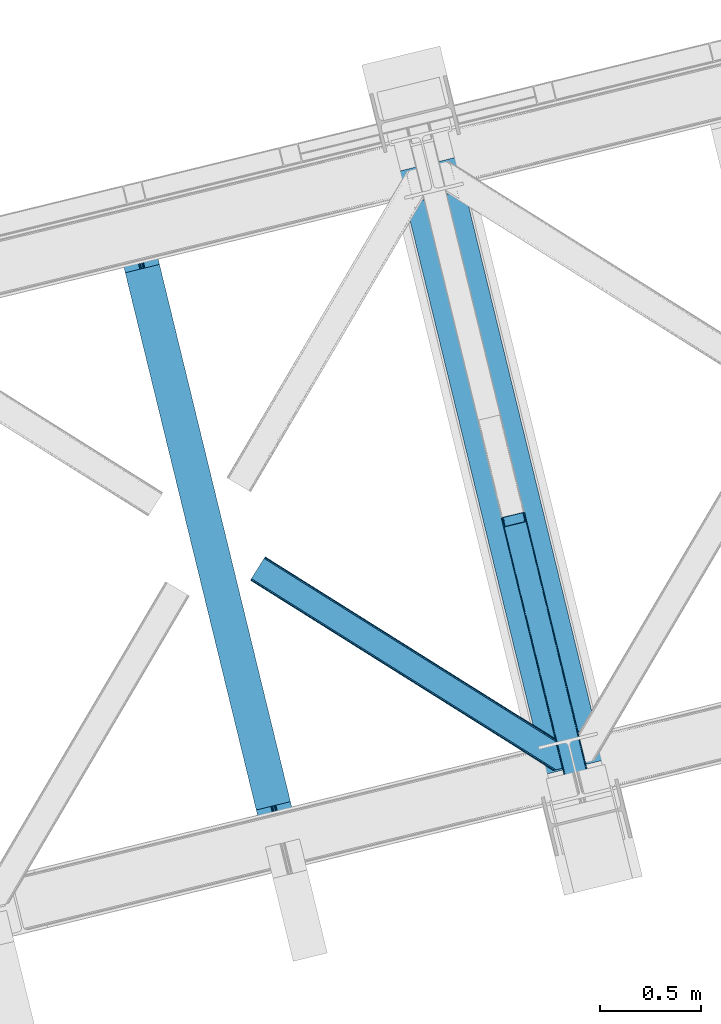
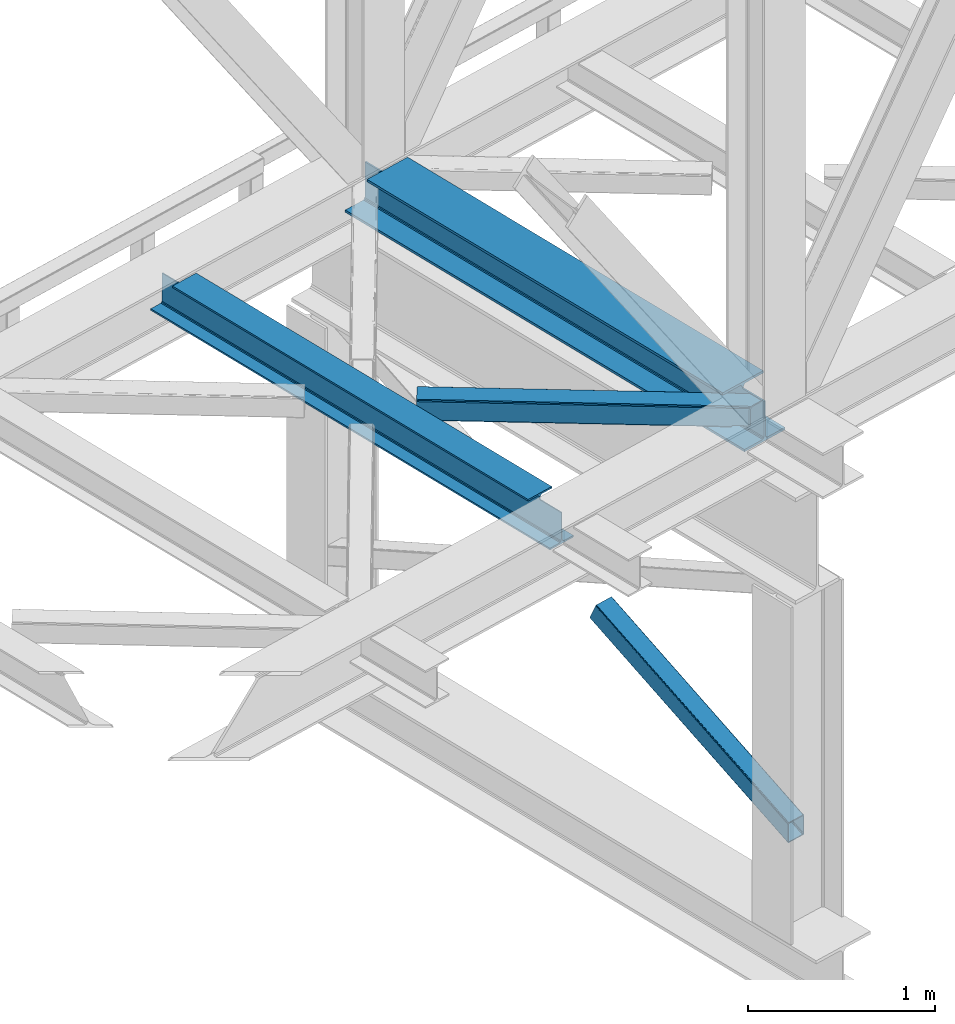
# One storey, part 28 of 93: 2 beams, 2 members.
"""IFC4 building model written with IfcOpenShell, lengths in millimetres."""

import ifcopenshell
import ifcopenshell.guid

model = None  # the IFC model being written
_history = None  # IfcOwnerHistory: only IFC2X3 demands one
_inside = {}  # id of a spatial element -> (the spatial element, [elements in it])
_under = {}  # id of a project, library or spatial element -> (it, [spatial elements below it])
_declared = {}  # id of a project -> (the project, [libraries it declares])
_typed = {}  # id of a type object -> (the type object, [elements of that type])
_made_of = {}  # id of a material, layer set ... -> (it, [elements and type objects made of it])


def new_model(schema):
    """Start an empty IFC model of exactly this schema.

    Asked for "IFC4X3", IfcOpenShell would pick the latest addendum, in which some entities
    have other attributes; the version numbers below select the first issue.
    IFC2X3 requires an IfcOwnerHistory on every rooted entity: one is made here for all.
    """
    global model, _history
    if schema == "IFC4X3":
        model = ifcopenshell.file(schema_version=(4, 3, 0, 0))
    else:
        model = ifcopenshell.file(schema=schema)
    _inside.clear()
    _under.clear()
    _declared.clear()
    _typed.clear()
    _made_of.clear()
    _history = None
    if model.schema == "IFC2X3":
        org = make("IfcOrganization", Name="unknown")
        user = make(
            "IfcPersonAndOrganization",
            ThePerson=make("IfcPerson", FamilyName="unknown"),
            TheOrganization=org,
        )
        app = make(
            "IfcApplication",
            ApplicationDeveloper=org,
            Version="unknown",
            ApplicationFullName="unknown",
            ApplicationIdentifier="unknown",
        )
        _history = make(
            "IfcOwnerHistory",
            OwningUser=user,
            OwningApplication=app,
            ChangeAction="ADDED",
            CreationDate=0,
        )
    return model


def make(cls, **values):
    """One entity of the class cls with the attributes given. An attribute that is None is left unset."""
    return model.create_entity(
        cls, **{name: value for name, value in values.items() if value is not None}
    )


def entity(cls, *values):
    """Any entity or typed value of the class cls, its attributes in the order of the schema. None: left unset."""
    e = model.create_entity(cls)
    for i, value in enumerate(values):
        if value is not None:
            e[i] = value
    return e


def rooted(cls, **values):
    """An entity with a GlobalId (a new one), such as an element, a storey or a relation."""
    return make(cls, GlobalId=ifcopenshell.guid.new(), OwnerHistory=_history, **values)


def si_unit(unit_type, name, prefix=None):
    """IfcSIUnit, for example si_unit("LENGTHUNIT", "METRE", prefix="MILLI")."""
    return make("IfcSIUnit", UnitType=unit_type, Prefix=prefix, Name=name)


def converted_unit(unit_type, name, factor, base, dimensions=None, offset=None):
    """IfcConversionBasedUnit, such as the inch: factor (a typed value) times the base unit."""
    return make(
        "IfcConversionBasedUnit"
        if offset is None
        else "IfcConversionBasedUnitWithOffset",
        ConversionOffset=offset,
        Dimensions=None
        if dimensions is None
        else entity("IfcDimensionalExponents", *dimensions),
        UnitType=unit_type,
        Name=name,
        ConversionFactor=make(
            "IfcMeasureWithUnit", ValueComponent=factor, UnitComponent=base
        ),
    )


def derived_unit(unit_type, elements):
    """IfcDerivedUnit: a product of units, each with its exponent."""
    return make(
        "IfcDerivedUnit",
        Elements=[
            make("IfcDerivedUnitElement", Unit=unit, Exponent=power)
            for unit, power in elements
        ],
        UnitType=unit_type,
    )


def assignment(units):
    """IfcUnitAssignment: the units of a project."""
    return None if units is None else make("IfcUnitAssignment", Units=units)


def point(xyz):
    """IfcCartesianPoint."""
    return None if xyz is None else make("IfcCartesianPoint", Coordinates=xyz)


def direction(xyz):
    """IfcDirection."""
    return None if xyz is None else make("IfcDirection", DirectionRatios=xyz)


def frame(location, z_axis=None, x_axis=None):
    """IfcAxis2Placement3D, a coordinate frame: its origin and axes. An axis left out is left unset."""
    return make(
        "IfcAxis2Placement3D",
        Location=point(location),
        Axis=direction(z_axis),
        RefDirection=direction(x_axis),
    )


def origin():
    """The frame at (0, 0, 0) with its axes left unset."""
    return frame((0.0, 0.0, 0.0))


def place(relative_to, where):
    """IfcLocalPlacement: puts the frame where relative to a parent placement (None: the world)."""
    return make(
        "IfcLocalPlacement", PlacementRelTo=relative_to, RelativePlacement=where
    )


def context(
    kind, dimensions, precision=None, world=None, true_north=None, identifier=None
):
    """IfcGeometricRepresentationContext, for example the 3D "Model" context."""
    return make(
        "IfcGeometricRepresentationContext",
        ContextIdentifier=identifier,
        ContextType=kind,
        CoordinateSpaceDimension=dimensions,
        Precision=precision,
        WorldCoordinateSystem=world,
        TrueNorth=true_north,
    )


def subcontext(parent, identifier, kind, view, scale=None):
    """IfcGeometricRepresentationSubContext, for example "Body" below "Model"."""
    return make(
        "IfcGeometricRepresentationSubContext",
        ContextIdentifier=identifier,
        ContextType=kind,
        ParentContext=parent,
        TargetScale=scale,
        TargetView=view,
    )


def project(units=None, contexts=None):
    """IfcProject with its units and contexts."""
    return rooted(
        "IfcProject",
        Name="project",
        RepresentationContexts=contexts,
        UnitsInContext=assignment(units),
    )


def spatial(cls, under=None, at=None, **own):
    """A site, building, storey or space (cls), placed at a placement, below another one or the project."""
    s = rooted(cls, ObjectPlacement=at, **own)
    if under is not None:
        _under.setdefault(under.id(), (under, []))[1].append(s)
    return s


def point_list(points):
    """IfcCartesianPointList2D or 3D."""
    cls = (
        "IfcCartesianPointList2D" if len(points[0]) == 2 else "IfcCartesianPointList3D"
    )
    return make(cls, CoordList=points)


def triangles(points, corners, closed=None, point_numbers=None):
    """IfcTriangulatedFaceSet: each triangle names its three corners, points numbered from 1."""
    return make(
        "IfcTriangulatedFaceSet",
        Coordinates=point_list(points),
        Closed=closed,
        CoordIndex=corners,
        PnIndex=point_numbers,
    )


def polygons(points, faces, closed=None, point_numbers=None):
    """IfcPolygonalFaceSet: a face is its outer loop, then its inner loops; points numbered from 1."""
    made = []
    for loops in faces:
        if len(loops) == 1:
            made.append(make("IfcIndexedPolygonalFace", CoordIndex=loops[0]))
        else:
            made.append(
                make(
                    "IfcIndexedPolygonalFaceWithVoids",
                    CoordIndex=loops[0],
                    InnerCoordIndices=loops[1:],
                )
            )
    return make(
        "IfcPolygonalFaceSet",
        Coordinates=point_list(points),
        Closed=closed,
        Faces=made,
        PnIndex=point_numbers,
    )


def shape(context_of_items, identifier, shape_type, items):
    """IfcShapeRepresentation: the items that make up one representation, for example the "Body"."""
    return make(
        "IfcShapeRepresentation",
        ContextOfItems=context_of_items,
        RepresentationIdentifier=identifier,
        RepresentationType=shape_type,
        Items=items,
    )


def material(Name=None, Category=None):
    """IfcMaterial."""
    return make("IfcMaterial", Name=Name, Category=Category)


def made_of(thing, what):
    """Note that an element or type object is made of a material, layer set ...; save() writes the relation."""
    if what is not None:
        _made_of.setdefault(what.id(), (what, []))[1].append(thing)
    return thing


def type_object(cls, material=None, **own):
    """A type object (cls), such as IfcWallType, which elements share."""
    return made_of(rooted(cls, **own), material)


def element(
    cls,
    number,
    at=None,
    inside=None,
    cuts=None,
    type_object=None,
    material=None,
    context=None,
    identifier="Body",
    shape_type=None,
    held_by="IfcProductDefinitionShape",
    body=None,
    shapes=None,
    **own,
):
    """One element of the class cls, such as IfcWall. Its Tag is "e" and its number.

    at: its placement. inside: the storey or other place that contains it. cuts: it is an
    opening in that element (IfcRelVoidsElement). A single representation is given by context,
    identifier, shape_type and body (its items); several are given by shapes. held_by: the class
    of the entity that holds the representations. save() writes the other relations.
    """
    e = rooted(cls, Tag="e%d" % number, ObjectPlacement=at, **own)
    if body is not None:
        shapes = [shape(context, identifier, shape_type, body)]
    if shapes is not None:
        e.Representation = make(held_by, Representations=shapes)
    if inside is not None:
        _inside.setdefault(inside.id(), (inside, []))[1].append(e)
    if cuts is not None:
        rooted(
            "IfcRelVoidsElement", RelatingBuildingElement=cuts, RelatedOpeningElement=e
        )
    if type_object is not None:
        _typed.setdefault(type_object.id(), (type_object, []))[1].append(e)
    return made_of(e, material)


def aggregate(whole, parts):
    """IfcRelAggregates: a whole, such as a stair, and the parts it consists of."""
    return rooted("IfcRelAggregates", RelatingObject=whole, RelatedObjects=parts)


def save(model, path):
    """Write the relations noted so far, then the file.

    IfcRelAggregates (storeys below a building ...), IfcRelContainedInSpatialStructure (elements
    in a storey), IfcRelDefinesByType, IfcRelAssociatesMaterial and IfcRelDeclares: one each for
    every whole, place, type object, material and project.
    """
    for whole, parts in _under.values():
        aggregate(whole, parts)
    for where, things in _inside.values():
        rooted(
            "IfcRelContainedInSpatialStructure",
            RelatedElements=things,
            RelatingStructure=where,
        )
    for kind, things in _typed.values():
        rooted("IfcRelDefinesByType", RelatedObjects=things, RelatingType=kind)
    for what, things in _made_of.values():
        rooted("IfcRelAssociatesMaterial", RelatedObjects=things, RelatingMaterial=what)
    for by, libraries in _declared.values():
        rooted("IfcRelDeclares", RelatingContext=by, RelatedDefinitions=libraries)
    model.write(path)


model = new_model("IFC4")

# Units and contexts
model_context = context("Model", 3, precision=0.01, world=origin(), true_north=direction((6.12303176911189e-17, 1.0)))
plan_context = context("Plan", 3, precision=0.01, world=origin(), true_north=direction((6.12303176911189e-17, 1.0)))
body_context = subcontext(model_context, "Body", "Model", "MODEL_VIEW")
ifc_project = project(units=[si_unit("LENGTHUNIT", "METRE", prefix="MILLI"), si_unit("AREAUNIT", "SQUARE_METRE"), si_unit("VOLUMEUNIT", "CUBIC_METRE"), converted_unit("PLANEANGLEUNIT", "DEGREE", entity("IfcRatioMeasure", 0.0174532925199433), si_unit("PLANEANGLEUNIT", "RADIAN"), dimensions=[0, 0, 0, 0, 0, 0, 0]), si_unit("MASSUNIT", "GRAM", prefix="KILO"), derived_unit("MASSDENSITYUNIT", [(si_unit("MASSUNIT", "GRAM", prefix="KILO"), 1), (si_unit("LENGTHUNIT", "METRE"), -3)]), derived_unit("MOMENTOFINERTIAUNIT", [(si_unit("LENGTHUNIT", "METRE"), 4)]), si_unit("TIMEUNIT", "SECOND"), si_unit("FREQUENCYUNIT", "HERTZ"), si_unit("THERMODYNAMICTEMPERATUREUNIT", "DEGREE_CELSIUS"), derived_unit("THERMALTRANSMITTANCEUNIT", [(si_unit("MASSUNIT", "GRAM", prefix="KILO"), 1), (si_unit("THERMODYNAMICTEMPERATUREUNIT", "KELVIN"), -1), (si_unit("TIMEUNIT", "SECOND"), -3)]), derived_unit("VOLUMETRICFLOWRATEUNIT", [(si_unit("LENGTHUNIT", "METRE"), 3), (si_unit("TIMEUNIT", "SECOND"), -1)]), derived_unit("MASSFLOWRATEUNIT", [(si_unit("MASSUNIT", "GRAM", prefix="KILO"), 1), (si_unit("TIMEUNIT", "SECOND"), -1)]), derived_unit("ROTATIONALFREQUENCYUNIT", [(si_unit("TIMEUNIT", "SECOND"), -1)]), si_unit("ELECTRICCURRENTUNIT", "AMPERE"), si_unit("ELECTRICVOLTAGEUNIT", "VOLT"), si_unit("POWERUNIT", "WATT"), si_unit("FORCEUNIT", "NEWTON", prefix="KILO"), si_unit("ILLUMINANCEUNIT", "LUX"), si_unit("LUMINOUSFLUXUNIT", "LUMEN"), si_unit("LUMINOUSINTENSITYUNIT", "CANDELA"), derived_unit("USERDEFINED", [(si_unit("MASSUNIT", "GRAM", prefix="KILO"), -1), (si_unit("LENGTHUNIT", "METRE"), -2), (si_unit("TIMEUNIT", "SECOND"), 3), (si_unit("LUMINOUSFLUXUNIT", "LUMEN"), 1)]), derived_unit("LINEARVELOCITYUNIT", [(si_unit("LENGTHUNIT", "METRE"), 1), (si_unit("TIMEUNIT", "SECOND"), -1)]), si_unit("PRESSUREUNIT", "PASCAL"), derived_unit("USERDEFINED", [(si_unit("LENGTHUNIT", "METRE"), -2), (si_unit("MASSUNIT", "GRAM", prefix="KILO"), 1), (si_unit("TIMEUNIT", "SECOND"), -2)]), derived_unit("LINEARFORCEUNIT", [(si_unit("MASSUNIT", "GRAM", prefix="KILO"), 1), (si_unit("LENGTHUNIT", "METRE"), 1), (si_unit("TIMEUNIT", "SECOND"), -2), (si_unit("LENGTHUNIT", "METRE"), -1)]), derived_unit("PLANARFORCEUNIT", [(si_unit("MASSUNIT", "GRAM", prefix="KILO"), 1), (si_unit("LENGTHUNIT", "METRE"), 1), (si_unit("TIMEUNIT", "SECOND"), -2), (si_unit("LENGTHUNIT", "METRE"), -2)])], contexts=[model_context, plan_context])

# Site, building, storey
site_placement = place(None, origin())
site = spatial("IfcSite", under=ifc_project, at=site_placement, CompositionType="ELEMENT")
building_placement = place(site_placement, origin())
building = spatial("IfcBuilding", under=site, at=building_placement, CompositionType="ELEMENT")
storey_placement = place(building_placement, frame((0.0, 0.0, 15900.0)))
storey = spatial("IfcBuildingStorey", under=building, at=storey_placement, CompositionType="ELEMENT", Elevation=15900.0)

# Beams
ifc_material = material(Name="Metal painted (White)")
beam_type = type_object("IfcBeamType", PredefinedType="BEAM")
beam_1_placement = place(storey_placement, frame((-56721.2326653712, 3960.30424291237, 3441.0)))
element("IfcBeam", 1, at=beam_1_placement, inside=storey, type_object=beam_type, material=ifc_material, ObjectType="Steel Beam", PredefinedType="BEAM", context=body_context, shape_type="Tessellation", body=[
    polygons([(900.985346189432, 41.4445662733087, 11.000000000004), (900.985346189432, 41.4445662733087, 2.16573425859679e-12), (170.021610174752, 3040.13999372697, 2.16573425859679e-12), (170.021610174752, 3040.13999372697, 11.000000000004), (834.919806235814, 25.3403919499662, 11.000000000004), (103.956070221135, 3024.03581940363, 11.000000000004), (828.971056214522, 23.8903211957401, 12.2179274798217), (98.0073201998427, 3022.5857486494, 12.2179274798217), (823.927949458422, 22.6610105689194, 15.6862915010192), (92.9642134437254, 3021.35643802258, 15.6862915010192), (820.558253255237, 21.8396114687119, 20.8770650821657), (89.5945172405581, 3020.53503892237, 20.8770650821657), (819.374973305543, 21.5511744621206, 27.0000000000047), (88.4112372908723, 3020.24660191578, 27.0000000000047), (81.6103728838801, 3018.58881926485, 27.0000000000047), (81.6103728838801, 3018.58881926485, 203.000000000006), (88.4112372908636, 3020.24660191578, 203.000000000006), (-8.66293703438714e-12, 2998.69542745366, 2.16573425859679e-12), (-8.66293703438714e-12, 2998.69542745366, 10.9999999999997), (66.0655399536172, 3014.799601777, 11.000000000004), (72.0142899749097, 3016.24967253123, 12.2179274798217), (77.0573967310183, 3017.47898315805, 15.6862915010192), (80.4270929341942, 3018.30038225826, 20.8770650821657), (819.374973305543, 21.5511744621195, 203.000000000006), (812.574108898559, 19.8933918111881, 203.000000000006), (812.574108898559, 19.8933918111881, 27.0000000000047), (811.390828948873, 19.6049548045968, 20.8770650821657), (808.021132745689, 18.7835557043887, 15.6862915010192), (802.978025989589, 17.5542450775691, 12.2179274798217), (797.029275968279, 16.1041743233431, 11.000000000004), (730.963736014671, -1.08286712929839e-12, 10.9999999999997), (730.963736014662, 0.0, 2.16573425859679e-12), (779.675212882749, 184.415062601691, 203.069791966819), (128.020401343495, 2857.75452019162, 203.000000000006), (128.243282132641, 2856.84017775719, 203.617301946336), (128.256196377177, 2856.7871977843, 217.000003693143), (779.530009633815, 185.010597404071, 217.000003676718), (779.530880241713, 185.007025963191, 204.00000679514), (772.964911718311, 182.385463974442, 203.006342981529), (772.742064056773, 183.299815969774, 203.617301946336), (772.729149812254, 183.352795942667, 217.000003693143), (121.455336555599, 2855.1293963229, 217.000003676718), (121.45446594771, 2855.13296776378, 204.00000679514), (121.310166358655, 2855.72494066435, 203.076120467494), (121.219536936503, 2856.09673754069, 203.000000000006), (780.71349435786, 185.298194377514, 223.122939328039), (784.08249076653, 186.122464201393, 228.313710402595), (789.125126170554, 187.353708426698, 231.782072735464), (795.073705041258, 188.80448128138, 232.999999602236), (861.139155906781, 204.909021065315, 232.999999283132), (861.137682570343, 204.915065042187, 243.999994005812), (691.116301666422, 163.469558245298, 243.999994827032), (691.117775002877, 163.463514268424, 233.000000104353), (757.183225868383, 179.568054052358, 232.999999785253), (763.132130996713, 181.017488520583, 231.782072861016), (768.175695503853, 182.244921343717, 228.313710479427), (771.546082413585, 183.063487001147, 223.12293937232), (120.271851831572, 2854.84179934945, 223.122939328039), (116.902855422893, 2854.01752952557, 228.313710402595), (111.860220018869, 2852.78628530027, 231.782072735464), (105.911641148157, 2851.33551244559, 232.999999602236), (39.8461902826332, 2835.23097266165, 232.999999283128), (39.8476636190708, 2835.22492868478, 243.999994005812), (209.869044522992, 2876.67043548167, 243.999994827032), (209.867571186554, 2876.67647945854, 233.000000104357), (143.802120321031, 2860.57193967461, 232.999999785253), (137.853215192701, 2859.12250520638, 231.782072861012), (132.809650685561, 2857.89507238325, 228.313710479427), (129.43926377583, 2857.07650672582, 223.12293937232)], [[[1, 2, 3, 4]], [[5, 1, 4, 6]], [[7, 5, 6, 8]], [[9, 7, 8, 10]], [[11, 9, 10, 12]], [[13, 11, 12, 14]], [[15, 16, 17, 14, 12, 10, 8, 6, 4, 3, 18, 19, 20, 21, 22, 23]], [[13, 24, 25, 26, 27, 28, 29, 30, 31, 32, 2, 1, 5, 7, 9, 11]], [[2, 32, 18, 3]], [[32, 31, 19, 18]], [[31, 30, 20, 19]], [[27, 26, 15, 23]], [[28, 27, 23, 22]], [[29, 28, 22, 21]], [[30, 29, 21, 20]], [[33, 24, 13, 14, 17, 34, 35, 36, 37, 38]], [[25, 39, 40, 41, 42, 43, 44, 16, 15, 26]], [[39, 25, 24, 33]], [[45, 34, 17, 16]], [[41, 40, 38, 37, 46, 47, 48, 49, 50, 51, 52, 53, 54, 55, 56, 57]], [[42, 58, 59, 60, 61, 62, 63, 64, 65, 66, 67, 68, 69, 36, 35, 43]], [[46, 37, 36, 69]], [[47, 46, 69, 68]], [[48, 47, 68, 67]], [[49, 48, 67, 66]], [[50, 49, 66, 65]], [[51, 50, 65, 64]], [[52, 51, 64, 63]], [[53, 52, 63, 62]], [[54, 53, 62, 61]], [[55, 54, 61, 60]], [[56, 55, 60, 59]], [[57, 56, 59, 58]], [[41, 57, 58, 42]]], closed=False),
])
beam_2_placement = place(storey_placement, frame((-55324.6265817928, 4300.74175158598, 3385.0)))
element("IfcBeam", 2, at=beam_2_placement, inside=storey, type_object=beam_type, material=ifc_material, ObjectType="Steel Beam", PredefinedType="BEAM", context=body_context, shape_type="Tessellation", body=[
    polygons([(1022.42935345713, 71.0478278971016, 15.4999999999986), (1022.42935345713, 71.0478278971016, 0.0), (291.465617442446, 3069.74325535076, 0.0), (291.465617442446, 3069.74325535076, 15.4999999999986), (899.042242073153, 40.9709140873286, 15.4999999999986), (168.078506058482, 3039.66634154099, 15.4999999999986), (892.349898299199, 39.3395844888243, 16.8701684147963), (161.38616228452, 3038.03501194248, 16.8701684147963), (886.676403198583, 37.956610033653, 20.7720779386413), (155.712667183904, 3036.65203748731, 20.7720779386413), (882.885494970008, 37.0325360459184, 26.6116982174294), (151.921758955329, 3035.72796349958, 26.6116982174294), (881.554305026603, 36.7080444135029, 33.500000000001), (150.590569011941, 3035.40347186716, 33.500000000001), (140.875048430531, 3033.03521093726, 33.500000000001), (140.875048430514, 3033.03521093726, 259.000000000002), (150.590569011924, 3035.40347186716, 259.000000000002), (8.66293703438714e-12, 2998.69542745366, 0.0), (8.66293703438714e-12, 2998.69542745366, 15.4999999999986), (123.387111383972, 3028.77234126343, 15.4999999999986), (130.079455157918, 3030.40367086194, 16.8701684147963), (135.752950258551, 3031.78664531711, 20.7720779386413), (139.543858487126, 3032.71071930484, 26.6116982174294), (881.554305026603, 36.7080444135024, 259.000000000002), (871.838784445193, 34.3397834836003, 259.000000000002), (871.838784445193, 34.3397834836003, 33.500000000001), (870.507594501796, 34.0152918511848, 26.6116982174294), (866.716686273221, 33.0912178634502, 20.7720779386413), (861.043191172614, 31.7082434082778, 16.8701684147963), (854.350847398652, 30.0769138097741, 15.4999999999986), (730.963736014679, 1.08286712929839e-12, 15.4999999999986), (730.963736014679, 0.0, 0.0), (841.85453458624, 199.57193011123, 259.069791776412), (190.199733064564, 2872.911390143, 259.000000000002), (190.423126166404, 2871.99494573803, 259.61730333112), (190.43551501003, 2871.94412150426, 266.500003008253), (841.70935577274, 200.167408132524, 266.500002998871), (841.709705893492, 200.16597182779, 260.000004007589), (832.229597305445, 196.831858094285, 259.006343172366), (832.006227290704, 197.748309612731, 259.61730333112), (831.993838447078, 197.799133846505, 266.500003008253), (180.719997684385, 2869.57584721824, 266.500002998871), (180.719647563633, 2869.57728352297, 260.000004007589), (180.574841905289, 2870.17133233676, 259.07612046749), (180.484212483145, 2870.5431292131, 259.000000000002), (843.040843642659, 200.49067757721, 273.388305639783), (846.831120231363, 201.417342749123, 279.227924098781), (852.504191178893, 202.802057212799, 283.129832400619), (859.196382860027, 204.434010743612, 284.500000377228), (982.583411547879, 234.511263798724, 284.500000138971), (982.58174174121, 234.518113867455, 299.999995328161), (691.11631964394, 163.469484603413, 299.999995890962), (691.1179894506, 163.462634534682, 284.500000701776), (814.505018138444, 193.539887589793, 284.500000463519), (821.197505034592, 195.170630056372, 283.129832461069), (826.871416683343, 196.551895700897, 279.227924137322), (830.662951470344, 197.473399350194, 273.388305663684), (179.388509814458, 2869.25257777355, 273.388305639783), (175.598233225771, 2868.32591260164, 279.227924098781), (169.925162278232, 2866.94119813796, 283.129832400619), (163.232970597099, 2865.30924460715, 284.500000377228), (39.8459419092461, 2835.23199155204, 284.500000138971), (39.8476117159065, 2835.22514148331, 299.999995328161), (331.313033813185, 2906.27377074735, 299.999995890962), (331.311364006534, 2906.28062081608, 284.500000701776), (207.924335318681, 2876.20336776097, 284.500000463519), (201.231848422542, 2874.57262529439, 283.129832461069), (195.557936773773, 2873.19135964987, 279.227924137322), (191.76640198679, 2872.26985600057, 273.388305663684)], [[[1, 2, 3, 4]], [[5, 1, 4, 6]], [[7, 5, 6, 8]], [[9, 7, 8, 10]], [[11, 9, 10, 12]], [[13, 11, 12, 14]], [[15, 16, 17, 14, 12, 10, 8, 6, 4, 3, 18, 19, 20, 21, 22, 23]], [[13, 24, 25, 26, 27, 28, 29, 30, 31, 32, 2, 1, 5, 7, 9, 11]], [[2, 32, 18, 3]], [[32, 31, 19, 18]], [[31, 30, 20, 19]], [[27, 26, 15, 23]], [[28, 27, 23, 22]], [[29, 28, 22, 21]], [[30, 29, 21, 20]], [[33, 24, 13, 14, 17, 34, 35, 36, 37, 38]], [[25, 39, 40, 41, 42, 43, 44, 16, 15, 26]], [[39, 25, 24, 33]], [[45, 34, 17, 16]], [[41, 40, 38, 37, 46, 47, 48, 49, 50, 51, 52, 53, 54, 55, 56, 57]], [[42, 58, 59, 60, 61, 62, 63, 64, 65, 66, 67, 68, 69, 36, 35, 43]], [[46, 37, 36, 69]], [[47, 46, 69, 68]], [[48, 47, 68, 67]], [[49, 48, 67, 66]], [[50, 49, 66, 65]], [[51, 50, 65, 64]], [[52, 51, 64, 63]], [[53, 52, 63, 62]], [[54, 53, 62, 61]], [[55, 54, 61, 60]], [[56, 55, 60, 59]], [[57, 56, 59, 58]], [[41, 57, 58, 42]]], closed=False),
])

# Members
member_type_1 = type_object("IfcMemberType", PredefinedType="BRACE")
member_1_placement = place(storey_placement, frame((-54811.6497070313, 4087.91210632324, 911.279672241211)))
element("IfcMember", 3, at=member_1_placement, inside=storey, type_object=member_type_1, ObjectType="Steel Vertical Brace", PredefinedType="BRACE", context=body_context, shape_type="Tessellation", body=[
    triangles([(109.104968261723, 1516.67719116211, 692.224026489257), (472.287451171876, 26.7611572265623, 0.0), (369.303039550781, 1.65774765014658, 0.0), (6.12055664062791, 1491.57349090576, 692.224026489257), (115.806884765625, 1516.48185424805, 696.163320922849), (116.588232421876, 1515.53714447022, 698.605032348631), (479.087036132813, 28.4189048767093, 7.68092651366896), (114.113964843753, 1517.03007659912, 694.092517089841), (478.091748046878, 28.1761871337894, 4.96481323242188), (111.760620117188, 1517.09867706299, 692.710043334959), (477.096459960943, 27.9334693908695, 2.24986267089844), (474.691955566406, 27.3474586486818, 1.12551269531104), (126.913183593751, 1473.16763763428, 795.217739868163), (479.087036132813, 28.4189048767093, 123.979641723632), (123.345959472659, 1469.55913696289, 801.112728881835), (120.797277832033, 1468.71151428223, 801.59758300781), (472.287451171876, 26.7611572265623, 131.659405517577), (125.406298828129, 1470.70383453369, 799.729092407226), (474.691955566406, 27.3474586486818, 130.53505554199), (126.657385253908, 1471.97061767578, 797.659451293945), (477.096459960943, 27.9334693908695, 129.409542846679), (478.091748046878, 28.1761871337894, 126.694592285156), (369.303039550781, 1.65774765014658, 131.659405517577), (17.8128662109375, 1443.60839538574, 801.59758300781), (10.3296020507842, 1444.74844207764, 795.217739868163), (362.503454589845, 0.0, 123.979641723632), (363.498742675787, 0.242717742919922, 126.694592285156), (11.1062988281265, 1443.8037322998, 797.659451293945), (364.494030761722, 0.485435485839844, 129.409542846679), (12.8038696289077, 1443.25550994873, 799.729092407226), (366.898535156251, 1.07144622802753, 130.53505554199), (15.1572143554731, 1443.18690948486, 801.112728881835), (0.0, 1487.11794891357, 698.605032348631), (362.503454589845, 0.0, 7.68092651366896), (366.898535156251, 1.07144622802753, 1.12551269531104), (3.56722412109957, 1490.72644958496, 692.710043334959), (364.494030761722, 0.485435485839844, 2.24986267089844), (1.51153564453125, 1489.58175201416, 694.092517089841), (363.498742675787, 0.242717742919922, 4.96481323242188), (0.25579833984375, 1488.31496887207, 696.163320922849), (112.216406250001, 1512.35419921875, 703.161730957028), (111.439709472659, 1513.29890899658, 700.720019531247), (109.742138671878, 1513.84713134766, 698.650378417966), (104.733142089848, 1513.49482727051, 696.781887817382), (107.388793945313, 1513.91631317139, 697.266741943356), (120.062438964844, 1471.51773834229, 795.172393798828), (121.569323730473, 1473.98212280273, 790.661041259766), (121.313525390629, 1472.78510284424, 793.102752685547), (118.002099609381, 1470.37362213135, 796.55486755371), (115.453417968754, 1469.52599945068, 797.040884399412), (6.85539550781687, 1488.76784820557, 698.650378417966), (5.60430908203125, 1487.50048370361, 700.720019531247), (11.4644165039063, 1490.75958709717, 696.781887817382), (8.91573486328707, 1489.9119644165, 697.266741943356), (5.34385986328562, 1486.30346374512, 703.161730957028), (17.1756958007827, 1446.43787384033, 795.172393798828), (19.5290405273481, 1446.36927337646, 796.55486755371), (15.4781250000015, 1446.98667755127, 793.102752685547), (22.1846923828125, 1446.79075927734, 797.040884399412), (14.7014282226592, 1447.9313873291, 790.661041259766), (371.754052734381, 2.25567626953125, 125.048181152342), (374.158557128911, 2.8419776916503, 126.173693847653), (369.349548339844, 1.66966552734357, 123.923831176755), (367.358972167975, 1.18393936157236, 118.492767333984), (368.354260253909, 1.42665710449228, 121.208880615231), (472.236291503912, 26.7492393493649, 123.923831176755), (467.427282714845, 25.5772178649904, 126.173693847653), (469.831787109375, 26.1632286071781, 125.048181152342), (473.236230468756, 26.9922477722166, 121.208880615231), (474.23151855469, 27.2349655151365, 118.492767333984), (369.349548339844, 1.66966552734357, 7.73557434081886), (371.754052734381, 2.25567626953125, 6.61122436523146), (367.358972167975, 1.18393936157236, 13.166638183593), (368.354260253909, 1.42665710449228, 10.4505249023423), (374.158557128911, 2.8419776916503, 5.48571166992042), (472.236291503912, 26.7492393493649, 7.73557434081886), (473.236230468756, 26.9922477722166, 10.4505249023423), (469.831787109375, 26.1632286071781, 6.61122436523146), (474.23151855469, 27.2349655151365, 13.166638183593), (467.427282714845, 25.5772178649904, 5.48571166992042)], [[1, 2, 3], [3, 4, 1], [5, 6, 7], [8, 5, 9], [10, 8, 11], [1, 10, 12], [12, 2, 1], [11, 12, 10], [9, 11, 8], [7, 9, 5], [6, 13, 14], [14, 7, 6], [15, 16, 17], [18, 15, 19], [20, 18, 21], [13, 20, 22], [22, 14, 13], [21, 22, 20], [19, 21, 18], [17, 19, 15], [17, 16, 23], [24, 23, 16], [25, 26, 27], [28, 27, 29], [30, 29, 31], [32, 31, 23], [23, 24, 32], [31, 32, 30], [29, 30, 28], [27, 28, 25], [25, 33, 26], [34, 26, 33], [4, 3, 35], [36, 35, 37], [38, 37, 39], [40, 39, 34], [34, 33, 40], [39, 40, 38], [37, 38, 36], [35, 36, 4], [41, 6, 42], [43, 5, 8], [8, 10, 43], [6, 41, 13], [6, 5, 43], [43, 42, 6], [44, 1, 4], [1, 45, 43], [44, 45, 1], [1, 43, 10], [18, 46, 15], [47, 13, 41], [46, 20, 13], [48, 13, 47], [20, 46, 18], [46, 16, 15], [13, 48, 46], [46, 49, 16], [16, 50, 24], [50, 16, 49], [51, 33, 52], [4, 53, 44], [54, 4, 51], [4, 54, 53], [51, 4, 36], [55, 52, 33], [36, 38, 51], [40, 51, 38], [55, 33, 25], [40, 33, 51], [56, 32, 24], [57, 56, 24], [58, 25, 56], [59, 24, 50], [24, 59, 57], [30, 32, 56], [25, 60, 55], [28, 56, 25], [60, 25, 58], [56, 28, 30], [61, 62, 23], [27, 63, 31], [27, 31, 29], [23, 62, 17], [23, 31, 61], [63, 61, 31], [64, 26, 34], [26, 65, 63], [64, 65, 26], [26, 63, 27], [19, 66, 22], [67, 17, 62], [68, 19, 17], [68, 17, 67], [22, 21, 19], [66, 14, 22], [19, 68, 66], [66, 69, 14], [14, 70, 7], [70, 14, 69], [71, 35, 72], [34, 73, 64], [74, 34, 71], [34, 74, 73], [71, 34, 39], [72, 3, 75], [71, 39, 35], [35, 39, 37], [75, 3, 2], [35, 3, 72], [76, 9, 7], [77, 76, 7], [78, 12, 76], [79, 7, 70], [7, 79, 77], [12, 9, 76], [2, 80, 75], [12, 78, 2], [80, 2, 78], [11, 9, 12], [80, 44, 75], [53, 75, 44], [44, 80, 78], [45, 78, 76], [43, 76, 77], [42, 77, 79], [79, 41, 42], [77, 42, 43], [76, 43, 45], [78, 45, 44], [47, 41, 70], [79, 70, 41], [47, 70, 69], [48, 69, 66], [46, 66, 68], [49, 68, 67], [67, 50, 49], [68, 49, 46], [66, 46, 48], [69, 48, 47], [50, 67, 59], [62, 59, 67], [57, 59, 62], [56, 57, 61], [58, 56, 63], [60, 58, 65], [65, 64, 60], [63, 65, 58], [61, 63, 56], [62, 61, 57], [55, 60, 64], [64, 73, 55], [52, 55, 73], [51, 52, 74], [54, 51, 71], [53, 54, 72], [72, 75, 53], [71, 72, 54], [74, 71, 51], [73, 74, 52]]),
])
member_type_2 = type_object("IfcMemberType", PredefinedType="BRACE")
member_2_placement = place(storey_placement, frame((-56059.9967651367, 4319.81946258545, 3511.0000579834)))
element("IfcMember", 4, at=member_2_placement, inside=storey, type_object=member_type_2, ObjectType="Steel Horizontal Brace", PredefinedType="BRACE", context=body_context, shape_type="Tessellation", body=[
    triangles([(9.30640869140188, 960.453584289551, 0.0), (65.1262573242202, 1049.387109375, 0.0), (1387.64088134765, 219.293300628662, 0.0), (1423.32242431641, 72.9304321289064, 0.0), (1428.81511230468, 50.3934356689451, 10.8028289794929), (1429.26624755859, 48.5365722656252, 17.5000946044929), (0.0, 945.631233215332, 17.5000946044929), (0.711584472657705, 946.759652709961, 10.8028289794929), (1427.52681884765, 55.6814849853517, 5.12526855468968), (2.72541503905813, 949.972828674317, 5.12526855468968), (1425.59670410156, 63.5952461242678, 1.33247680664135), (5.74383544921875, 954.781256103515, 1.33247680664135), (68.6841796875015, 1055.05943756104, 1.33247680664135), (71.7026000976548, 1059.86786499023, 5.12526855468968), (1383.45043945313, 236.497483062744, 5.17061462402489), (73.7210815429644, 1063.08104095459, 10.8028289794929), (1388.24084472656, 238.005821228027, 10.8028289794929), (1390.04538574219, 238.445619964599, 17.5000946044929), (74.4280151367202, 1064.20946044922, 17.5000946044929), (1385.3666015625, 228.628195953369, 1.33247680664135), (1383.37137451172, 236.818393707275, 17.5198608398459), (1390.04538574219, 238.445619964599, 18.5197998046897), (1384.34340820312, 237.055007171631, 18.5197998046897), (1385.65030517578, 231.698357391358, 18.5197998046897), (1570.05300292969, 125.462400054932, 18.5197998046897), (1572.78771972656, 114.236631774902, 18.5197998046897), (1570.05300292969, 125.462400054932, 122.500662231447), (74.4280151367202, 1064.20946044922, 122.500662231447), (1570.50413818359, 123.605536651611, 129.197927856447), (73.7210815429644, 1063.08104095459, 129.197927856447), (1571.79708251953, 118.317487335205, 134.874325561526), (71.7026000976548, 1059.86786499023, 134.874325561526), (1573.72254638671, 110.403726196289, 138.667117309571), (68.6841796875015, 1055.05943756104, 138.667117309571), (1576.00147705078, 101.068540191651, 139.999594116212), (65.1262573242202, 1049.387109375, 139.999594116212), (67.9818969726548, 1053.93915710449, 12.1260040283232), (1385.8177368164, 226.784703826905, 12.1260040283232), (1384.56665039063, 231.905321502685, 17.5198608398459), (70.0003784179644, 1057.15175170898, 17.8035644531265), (1572.43425292968, 115.704856109619, 24.4996673583992), (70.7073120117202, 1058.28017120361, 24.4996673583992), (1387.7478515625, 218.870942687989, 8.3320495605476), (64.9634765625015, 1049.13014831543, 8.3320495605476), (1390.02213134766, 209.53575668335, 6.99957275390625), (61.4055541992202, 1043.45782012939, 6.99957275390625), (13.0271118164019, 966.382292175293, 6.99957275390625), (1420.9411743164, 82.6879760742186, 6.99957275390625), (1425.14556884766, 65.4390289306639, 12.1260040283232), (1426.39665527343, 60.3184112548824, 17.5198608398459), (1423.21545410156, 73.3527900695799, 8.3320495605476), (1572.43425292968, 115.704856109619, 115.501089477541), (70.7073120117202, 1058.28017120361, 115.501089477541), (1576.10379638672, 100.646182250976, 131.667544555665), (1578.37807617187, 91.3109962463377, 133.000021362306), (61.4055541992202, 1043.45782012939, 133.000021362306), (64.9634765625015, 1049.13014831543, 131.667544555665), (1574.17368164063, 108.560234069824, 127.87475280762), (67.9818969726548, 1053.93915710449, 127.87475280762), (1572.88538818359, 113.847992706299, 122.196029663086), (70.0003784179644, 1057.15175170898, 122.196029663086), (1595.3630859375, 21.6376327514645, 133.000021362306), (1595.3630859375, 21.6376327514645, 139.999594116212), (9.30640869140188, 960.453584289551, 139.999594116212), (1530.30659179687, 5.77958908081018, 139.999594116212), (1521.23272705078, 3.56780548095685, 138.667117309571), (5.74383544921875, 954.781256103515, 138.667117309571), (1513.54017333984, 1.69291992187482, 134.874325561526), (2.72541503905813, 949.972828674317, 134.874325561526), (1508.40095214843, 0.440089416503724, 129.197927856447), (0.711584472657705, 946.759652709961, 129.197927856447), (1506.59641113281, 0.0, 122.500662231447), (0.0, 945.631233215332, 122.500662231447), (1430.48012695312, 47.7738281250004, 18.5197998046897), (1506.59641113281, 0.0, 18.5197998046897), (1427.74541015625, 58.9995964050295, 18.5197998046897), (1517.50737304687, 2.65972137451172, 18.5197998046897), (3.72535400390188, 951.560522460937, 24.4996673583992), (1516.07955322265, 2.31206817626935, 24.4996673583992), (4.43228759765771, 952.688360595703, 17.8035644531265), (1427.07103271484, 59.6591491699219, 18.0198303222678), (6.45076904296729, 955.901536560059, 12.1260040283232), (9.46453857421875, 960.710545349121, 8.3320495605476), (6.45076904296729, 955.901536560059, 127.87475280762), (13.0271118164019, 966.382292175293, 133.000021362306), (9.46453857421875, 960.710545349121, 131.667544555665), (3.72535400390188, 951.560522460937, 115.501089477541), (4.43228759765771, 952.688360595703, 122.196029663086), (1530.71586914062, 5.87958297729529, 131.667544555665), (1523.02331542969, 4.00469741821325, 127.87475280762), (1517.88409423828, 2.75186691284216, 122.196029663086), (1539.78973388672, 8.09165725708044, 133.000021362306), (1516.07955322265, 2.31206817626935, 115.501089477541)], [[1, 2, 3], [3, 4, 1], [5, 6, 7], [7, 8, 5], [9, 5, 8], [8, 10, 9], [11, 9, 10], [10, 12, 11], [4, 11, 12], [12, 1, 4], [13, 14, 15], [16, 17, 15], [15, 14, 16], [18, 17, 19], [16, 19, 17], [20, 3, 2], [2, 13, 20], [15, 20, 13], [18, 21, 17], [18, 22, 23], [17, 21, 15], [21, 18, 23], [24, 22, 25], [22, 24, 23], [25, 26, 24], [25, 22, 27], [19, 22, 18], [22, 28, 27], [19, 28, 22], [29, 27, 30], [28, 30, 27], [31, 29, 32], [30, 32, 29], [33, 31, 34], [32, 34, 31], [35, 33, 36], [34, 36, 33], [37, 38, 39], [39, 40, 37], [24, 41, 42], [24, 26, 41], [42, 40, 39], [43, 38, 44], [37, 44, 38], [45, 43, 46], [44, 46, 43], [46, 47, 45], [48, 45, 47], [3, 48, 4], [43, 20, 38], [39, 15, 21], [15, 39, 38], [38, 20, 15], [43, 3, 20], [3, 45, 48], [43, 45, 3], [9, 49, 50], [50, 5, 9], [6, 5, 50], [49, 11, 51], [51, 4, 48], [4, 51, 11], [49, 9, 11], [41, 52, 53], [53, 42, 41], [54, 55, 56], [56, 57, 54], [58, 54, 57], [57, 59, 58], [60, 58, 59], [59, 61, 60], [52, 60, 61], [61, 53, 52], [58, 31, 33], [58, 33, 54], [55, 54, 35], [60, 31, 58], [62, 55, 63], [35, 63, 55], [54, 33, 35], [29, 31, 60], [25, 27, 52], [41, 25, 52], [25, 41, 26], [29, 60, 27], [60, 52, 27], [64, 35, 36], [35, 64, 65], [63, 35, 65], [66, 65, 64], [64, 67, 66], [68, 66, 67], [67, 69, 68], [70, 68, 69], [69, 71, 70], [72, 70, 71], [71, 73, 72], [74, 72, 6], [74, 75, 72], [73, 6, 72], [73, 7, 6], [74, 76, 77], [77, 75, 74], [78, 79, 76], [76, 80, 78], [76, 81, 80], [79, 77, 76], [50, 82, 80], [50, 49, 82], [51, 48, 83], [47, 83, 48], [49, 51, 82], [83, 82, 51], [16, 37, 40], [42, 28, 19], [16, 40, 19], [16, 14, 37], [40, 42, 19], [37, 14, 13], [46, 2, 1], [2, 44, 13], [44, 2, 46], [44, 37, 13], [30, 59, 32], [53, 28, 42], [28, 61, 30], [61, 28, 53], [30, 61, 59], [36, 56, 64], [34, 32, 59], [59, 57, 34], [57, 56, 36], [36, 34, 57], [82, 12, 10], [1, 47, 46], [1, 83, 47], [83, 1, 12], [82, 83, 12], [78, 7, 73], [8, 80, 82], [10, 8, 82], [80, 8, 7], [78, 80, 7], [67, 84, 69], [64, 56, 85], [85, 86, 64], [86, 84, 67], [67, 64, 86], [71, 69, 84], [73, 87, 78], [88, 73, 71], [73, 88, 87], [88, 71, 84], [89, 65, 66], [90, 66, 68], [91, 68, 70], [92, 63, 65], [89, 66, 90], [62, 63, 92], [89, 92, 65], [91, 90, 68], [72, 93, 91], [93, 72, 75], [79, 75, 77], [75, 79, 93], [72, 91, 70], [85, 55, 92], [85, 56, 55], [55, 62, 92], [91, 93, 88], [87, 88, 93], [90, 91, 84], [88, 84, 91], [89, 90, 86], [84, 86, 90], [92, 89, 85], [86, 85, 89], [93, 79, 78], [78, 87, 93]]),
])

save(model, "model.ifc")
